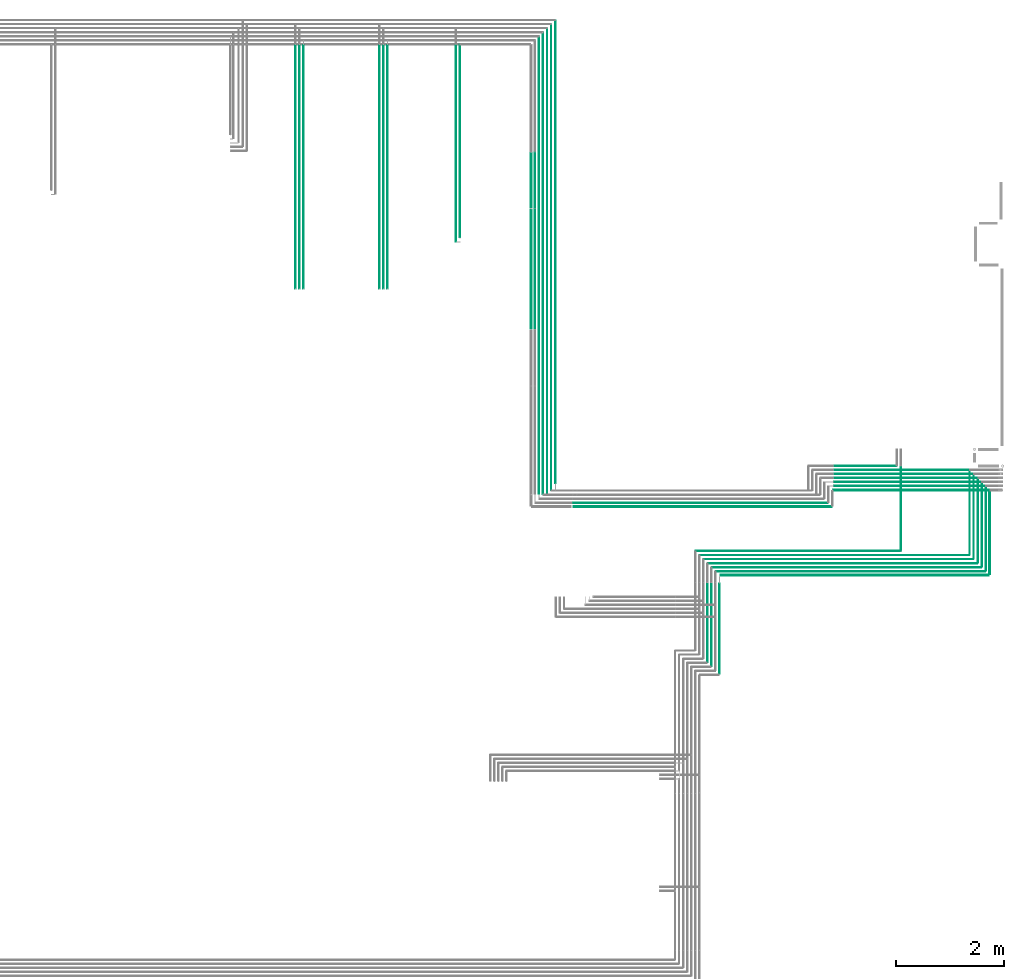
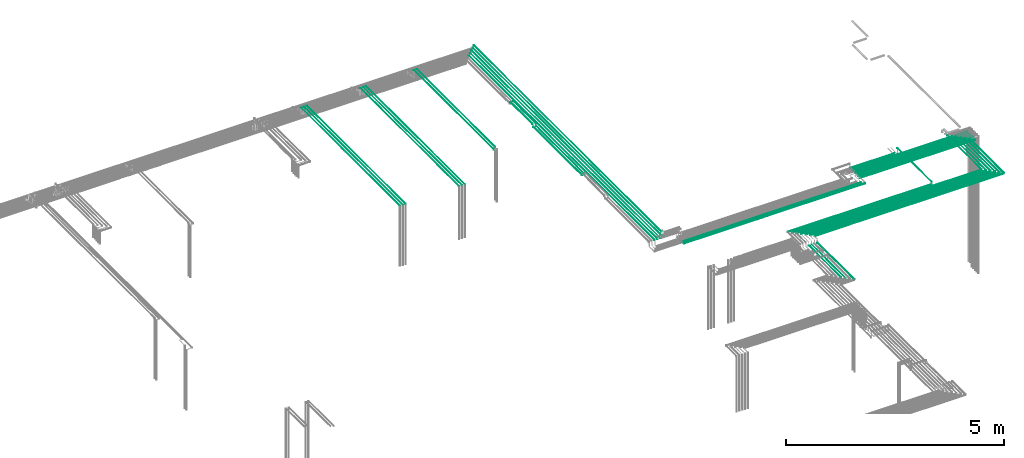
# One storey, part 30 of 89: 43 flow segments.
"""IFC2X3 building model written with IfcOpenShell, lengths in millimetres."""

from ifc_helpers import new_model, entity, si_unit, converted_unit, derived_unit, direction, frame, frame_2d, origin, origin_2d_with_axis, place, context, subcontext, project, spatial, circle, extrude, type_object, element, save


model = new_model("IFC2X3")

# Units and contexts
model_context = context("Model", 3, precision=0.01, world=origin(), true_north=direction((6.12303176911189e-17, 1.0)))
body_context = subcontext(model_context, "Body", "Model", "MODEL_VIEW")
ifc_project = project(units=[si_unit("LENGTHUNIT", "METRE", prefix="MILLI"), si_unit("AREAUNIT", "SQUARE_METRE"), si_unit("VOLUMEUNIT", "CUBIC_METRE"), converted_unit("PLANEANGLEUNIT", "DEGREE", entity("IfcRatioMeasure", 0.0174532925199433), si_unit("PLANEANGLEUNIT", "RADIAN"), dimensions=[0, 0, 0, 0, 0, 0, 0]), si_unit("MASSUNIT", "GRAM", prefix="KILO"), derived_unit("MASSDENSITYUNIT", [(si_unit("MASSUNIT", "GRAM", prefix="KILO"), 1), (si_unit("LENGTHUNIT", "METRE"), -3)]), derived_unit("MOMENTOFINERTIAUNIT", [(si_unit("LENGTHUNIT", "METRE"), 4)]), si_unit("TIMEUNIT", "SECOND"), si_unit("FREQUENCYUNIT", "HERTZ"), si_unit("THERMODYNAMICTEMPERATUREUNIT", "DEGREE_CELSIUS"), derived_unit("THERMALTRANSMITTANCEUNIT", [(si_unit("MASSUNIT", "GRAM", prefix="KILO"), 1), (si_unit("THERMODYNAMICTEMPERATUREUNIT", "KELVIN"), -1), (si_unit("TIMEUNIT", "SECOND"), -3)]), derived_unit("VOLUMETRICFLOWRATEUNIT", [(si_unit("LENGTHUNIT", "METRE"), 3), (si_unit("TIMEUNIT", "SECOND"), -1)]), derived_unit("MASSFLOWRATEUNIT", [(si_unit("MASSUNIT", "GRAM", prefix="KILO"), 1), (si_unit("TIMEUNIT", "SECOND"), -1)]), derived_unit("ROTATIONALFREQUENCYUNIT", [(si_unit("TIMEUNIT", "SECOND"), -1)]), si_unit("ELECTRICCURRENTUNIT", "AMPERE"), si_unit("ELECTRICVOLTAGEUNIT", "VOLT"), si_unit("POWERUNIT", "WATT"), si_unit("FORCEUNIT", "NEWTON", prefix="KILO"), si_unit("ILLUMINANCEUNIT", "LUX"), si_unit("LUMINOUSFLUXUNIT", "LUMEN"), si_unit("LUMINOUSINTENSITYUNIT", "CANDELA"), derived_unit("USERDEFINED", [(si_unit("MASSUNIT", "GRAM", prefix="KILO"), -1), (si_unit("LENGTHUNIT", "METRE"), -2), (si_unit("TIMEUNIT", "SECOND"), 3), (si_unit("LUMINOUSFLUXUNIT", "LUMEN"), 1)]), derived_unit("LINEARVELOCITYUNIT", [(si_unit("LENGTHUNIT", "METRE"), 1), (si_unit("TIMEUNIT", "SECOND"), -1)]), si_unit("PRESSUREUNIT", "PASCAL"), derived_unit("USERDEFINED", [(si_unit("LENGTHUNIT", "METRE"), -2), (si_unit("MASSUNIT", "GRAM", prefix="KILO"), 1), (si_unit("TIMEUNIT", "SECOND"), -2)]), derived_unit("LINEARFORCEUNIT", [(si_unit("MASSUNIT", "GRAM", prefix="KILO"), 1), (si_unit("LENGTHUNIT", "METRE"), 1), (si_unit("TIMEUNIT", "SECOND"), -2), (si_unit("LENGTHUNIT", "METRE"), -1)]), derived_unit("PLANARFORCEUNIT", [(si_unit("MASSUNIT", "GRAM", prefix="KILO"), 1), (si_unit("LENGTHUNIT", "METRE"), 1), (si_unit("TIMEUNIT", "SECOND"), -2), (si_unit("LENGTHUNIT", "METRE"), -2)])], contexts=[model_context])

# Site, building, storey
site_placement = place(None, frame((0.0, -0.00077364408347762, 0.0)))
site = spatial("IfcSite", under=ifc_project, at=site_placement, CompositionType="ELEMENT")
building_placement = place(site_placement, origin())
building = spatial("IfcBuilding", under=site, at=building_placement, CompositionType="ELEMENT")
storey_placement = place(building_placement, frame((0.0, 0.0, 24000.0)))
storey = spatial("IfcBuildingStorey", under=building, at=storey_placement, CompositionType="ELEMENT", Elevation=24000.0)

# Flow segments
pipe_segment_type = type_object("IfcPipeSegmentType", PredefinedType="NOTDEFINED")
flow_segment_1_placement = place(storey_placement, frame((73062.1514734655, 8793.95129953584, 2690.90472776409)))
element("IfcFlowSegment", 1, at=flow_segment_1_placement, inside=storey, type_object=pipe_segment_type, context=body_context, shape_type="SweptSolid", body=[
    extrude(circle(Radius=7.5, at=frame_2d((-8.66293703438714e-12, 0.0), x_axis=(1.0, 0.0))), frame((9.09527223594018, 0.0, 9.09527223591419), z_axis=(0.0, 1.0, 0.0), x_axis=(1.0, 0.0, 0.0)), (0.0, 0.0, 1.0), 1547.92034830156),
])
flow_segment_2_placement = place(storey_placement, frame((72916.050559081, 8935.95129953583, 2694.40472776409)))
element("IfcFlowSegment", 2, at=flow_segment_2_placement, inside=storey, type_object=pipe_segment_type, context=body_context, shape_type="SweptSolid", body=[
    extrude(circle(Radius=4.0, at=origin_2d_with_axis()), frame((5.59527223591499, 0.0, 5.59527223591499), z_axis=(0.0, 1.0, 0.0), x_axis=(1.0, 0.0, 0.0)), (0.0, 0.0, 1.0), 1563.74520630519),
])
flow_segment_3_placement = place(storey_placement, frame((72841.0505590676, 9010.95129953583, 2694.40472776409)))
element("IfcFlowSegment", 3, at=flow_segment_3_placement, inside=storey, type_object=pipe_segment_type, context=body_context, shape_type="SweptSolid", body=[
    extrude(circle(Radius=4.0, at=origin_2d_with_axis()), frame((5.59527223598429, 0.0, 5.59527223591499), z_axis=(0.0, 1.0, 0.0), x_axis=(1.0, 0.0, 0.0)), (0.0, 0.0, 1.0), 1563.98901522248),
])
flow_segment_4_placement = place(storey_placement, frame((72766.0505590676, 9085.95287992001, 2694.40472776415)))
element("IfcFlowSegment", 4, at=flow_segment_4_placement, inside=storey, type_object=pipe_segment_type, context=body_context, shape_type="SweptSolid", body=[
    extrude(circle(Radius=4.0, at=frame_2d((0.0, 6.10873375888857e-18), x_axis=(1.0, 0.0))), frame((5.59527223591499, 2.25650353826268e-05, 5.59527223585435), z_axis=(0.0, 1.0, 5.64125883370984e-06), x_axis=(-1.0, 0.0, 0.0)), (0.0, 0.0, 1.0), 1563.9225209192),
])
flow_segment_5_placement = place(storey_placement, frame((72691.0505590676, 9160.95129953583, 2694.40472776409)))
element("IfcFlowSegment", 5, at=flow_segment_5_placement, inside=storey, type_object=pipe_segment_type, context=body_context, shape_type="SweptSolid", body=[
    extrude(circle(Radius=4.0, at=origin_2d_with_axis()), frame((5.59527223591499, 0.0, 5.59527223591499), z_axis=(0.0, 1.0, 0.0), x_axis=(1.0, 0.0, 0.0)), (0.0, 0.0, 1.0), 1564.22554832766),
])
flow_segment_6_placement = place(storey_placement, frame((65334.0302365426, 10040.9047277637, 2665.90472776407)))
element("IfcFlowSegment", 6, at=flow_segment_6_placement, inside=storey, type_object=pipe_segment_type, context=body_context, shape_type="SweptSolid", body=[
    extrude(circle(Radius=7.5, at=frame_2d((-4.33146851719357e-12, 0.0), x_axis=(1.0, 0.0))), frame((0.0, 9.09527223591853, 9.09527223591419), z_axis=(1.0, 0.0, 0.0), x_axis=(0.0, 1.0, 0.0)), (0.0, 0.0, 1.0), 4792.68035740013),
])
flow_segment_7_placement = place(storey_placement, frame((67680.0002685548, 9145.35602729992, 2694.40472776408)))
element("IfcFlowSegment", 7, at=flow_segment_7_placement, inside=storey, type_object=pipe_segment_type, context=body_context, shape_type="SweptSolid", body=[
    extrude(circle(Radius=4.0, at=origin_2d_with_axis()), frame((0.0, 5.59527223594964, 5.59527223591499), z_axis=(1.0, 0.0, 0.0), x_axis=(0.0, -1.0, 0.0)), (0.0, 0.0, 1.0), 5006.6455627487),
])
flow_segment_8_placement = place(storey_placement, frame((72991.0505590676, 8860.9512995358, 2694.40472776409)))
element("IfcFlowSegment", 8, at=flow_segment_8_placement, inside=storey, type_object=pipe_segment_type, context=body_context, shape_type="SweptSolid", body=[
    extrude(circle(Radius=4.0, at=origin_2d_with_axis()), frame((5.59527224864085, 0.0, 5.59527223591499), z_axis=(0.0, 1.0, 0.0), x_axis=(1.0, 0.0, 0.0)), (0.0, 0.0, 1.0), 1556.86799522113),
])
flow_segment_9_placement = place(storey_placement, frame((65315.0302365425, 10119.4047277636, 2669.40472776407)))
element("IfcFlowSegment", 9, at=flow_segment_9_placement, inside=storey, type_object=pipe_segment_type, context=body_context, shape_type="SweptSolid", body=[
    extrude(circle(Radius=4.0, at=frame_2d((-4.54804194305325e-11, 0.0), x_axis=(1.0, 0.0))), frame((0.0, 5.59527223596264, 5.59527223591499), z_axis=(1.0, 0.0, 0.0), x_axis=(0.0, 1.0, 0.0)), (0.0, 0.0, 1.0), 4744.68035740013),
])
flow_segment_10_placement = place(storey_placement, frame((70162.7105939427, 10350.7766673957, 2615.90472776409)))
element("IfcFlowSegment", 10, at=flow_segment_10_placement, inside=storey, type_object=pipe_segment_type, context=body_context, shape_type="SweptSolid", body=[
    extrude(circle(Radius=7.5, at=frame_2d((2.16573425859679e-12, 0.0), x_axis=(1.0, 0.0))), frame((0.0, 9.09527223591853, 9.09527223591419), z_axis=(1.0, 0.0, 0.0), x_axis=(0.0, 1.0, 0.0)), (0.0, 0.0, 1.0), 3050.98693900199),
])
flow_segment_11_placement = place(storey_placement, frame((67830.0002685548, 8995.35602729992, 2694.40472776408)))
element("IfcFlowSegment", 11, at=flow_segment_11_placement, inside=storey, type_object=pipe_segment_type, context=body_context, shape_type="SweptSolid", body=[
    extrude(circle(Radius=4.0, at=origin_2d_with_axis()), frame((0.0, 5.59527223594964, 5.59527223591499), z_axis=(1.0, 0.0, 0.0), x_axis=(0.0, -1.0, 0.0)), (0.0, 0.0, 1.0), 5006.64556274878),
])
flow_segment_12_placement = place(storey_placement, frame((67905.0002685548, 8920.35602729992, 2694.40472776408)))
element("IfcFlowSegment", 12, at=flow_segment_12_placement, inside=storey, type_object=pipe_segment_type, context=body_context, shape_type="SweptSolid", body=[
    extrude(circle(Radius=4.0, at=origin_2d_with_axis()), frame((0.0, 5.59527223595073, 5.59527223591499), z_axis=(1.0, 0.0, 0.0), x_axis=(0.0, -1.0, 0.0)), (0.0, 0.0, 1.0), 5006.64556276213),
])
flow_segment_13_placement = place(storey_placement, frame((67755.0002685548, 9070.35763024912, 2694.40472776408)))
element("IfcFlowSegment", 13, at=flow_segment_13_placement, inside=storey, type_object=pipe_segment_type, context=body_context, shape_type="SweptSolid", body=[
    extrude(circle(Radius=4.0, at=origin_2d_with_axis()), frame((0.0, 5.5952722359269, 5.59527223591499), z_axis=(1.0, 0.0, 0.0), x_axis=(0.0, -1.0, 0.0)), (0.0, 0.0, 1.0), 5006.64556274871),
])
flow_segment_14_placement = place(storey_placement, frame((71415.5699397461, 9235.95129951454, 2744.40472776409)))
element("IfcFlowSegment", 14, at=flow_segment_14_placement, inside=storey, type_object=pipe_segment_type, context=body_context, shape_type="SweptSolid", body=[
    extrude(circle(Radius=4.0, at=origin_2d_with_axis()), frame((5.59527223591499, 0.0, 5.59527223591499), z_axis=(0.0, 1.0, 0.0), x_axis=(-1.0, 0.0, 0.0)), (0.0, 0.0, 1.0), 1563.91970228856),
])
flow_segment_15_placement = place(storey_placement, frame((68063.0002685548, 8766.85602729991, 2690.90472776408)))
element("IfcFlowSegment", 15, at=flow_segment_15_placement, inside=storey, type_object=pipe_segment_type, context=body_context, shape_type="SweptSolid", body=[
    extrude(circle(Radius=7.5, at=origin_2d_with_axis()), frame((0.0, 9.09527223591636, 9.09527223591419), z_axis=(1.0, 0.0, 0.0), x_axis=(0.0, -1.0, 0.0)), (0.0, 0.0, 1.0), 4990.24647714661),
])
flow_segment_16_placement = place(storey_placement, frame((68035.9049963189, 6943.0, 2590.90472776409)))
element("IfcFlowSegment", 16, at=flow_segment_16_placement, inside=storey, type_object=pipe_segment_type, context=body_context, shape_type="SweptSolid", body=[
    extrude(circle(Radius=7.5, at=origin_2d_with_axis()), frame((9.09527223595751, 0.0, 9.09527223591419), z_axis=(0.0, 1.0, 0.0), x_axis=(1.0, 0.0, 0.0)), (0.0, 0.0, 1.0), 1679.00000000001),
])
flow_segment_17_placement = place(storey_placement, frame((67980.0002685548, 8845.35602729992, 2694.40472776408)))
element("IfcFlowSegment", 17, at=flow_segment_17_placement, inside=storey, type_object=pipe_segment_type, context=body_context, shape_type="SweptSolid", body=[
    extrude(circle(Radius=4.0, at=origin_2d_with_axis()), frame((0.0, 5.5952722359269, 5.59527223591499), z_axis=(1.0, 0.0, 0.0), x_axis=(0.0, -1.0, 0.0)), (0.0, 0.0, 1.0), 5006.64556276142),
])
flow_segment_18_placement = place(storey_placement, frame((67889.4049963189, 7085.0, 2594.40472776409)))
element("IfcFlowSegment", 18, at=flow_segment_18_placement, inside=storey, type_object=pipe_segment_type, context=body_context, shape_type="SweptSolid", body=[
    extrude(circle(Radius=4.0, at=origin_2d_with_axis()), frame((5.59527223593232, 0.0, 5.59527223591499), z_axis=(0.0, 1.0, 0.0), x_axis=(1.0, 0.0, 0.0)), (0.0, 0.0, 1.0), 1545.00000000001),
])
flow_segment_19_placement = place(storey_placement, frame((67814.4049963189, 7160.0, 2594.40472776409)))
element("IfcFlowSegment", 19, at=flow_segment_19_placement, inside=storey, type_object=pipe_segment_type, context=body_context, shape_type="SweptSolid", body=[
    extrude(circle(Radius=4.0, at=origin_2d_with_axis()), frame((5.59527223593232, 0.0, 5.59527223591499), z_axis=(0.0, 1.0, 0.0), x_axis=(1.0, 0.0, 0.0)), (0.0, 0.0, 1.0), 1470.00000000001),
])
flow_segment_20_placement = place(storey_placement, frame((67605.0002685548, 9220.35602727861, 2694.40472776408)))
element("IfcFlowSegment", 20, at=flow_segment_20_placement, inside=storey, type_object=pipe_segment_type, context=body_context, shape_type="SweptSolid", body=[
    extrude(circle(Radius=4.0, at=origin_2d_with_axis()), frame((0.0, 5.59527223594964, 5.59527223591499), z_axis=(1.0, 0.0, 0.0), x_axis=(0.0, -1.0, 0.0)), (0.0, 0.0, 1.0), 3806.16494342721),
])
flow_segment_21_placement = place(storey_placement, frame((64984.2044210321, 10490.0, 2844.4047277641)))
element("IfcFlowSegment", 21, at=flow_segment_21_placement, inside=storey, type_object=pipe_segment_type, context=body_context, shape_type="SweptSolid", body=[
    extrude(circle(Radius=4.0, at=origin_2d_with_axis()), frame((5.59527223591499, 0.0, 5.59527223591499), z_axis=(0.0, 1.0, 0.0), x_axis=(-1.0, 0.0, 0.0)), (0.0, 0.0, 1.0), 8600.00000000001),
])
flow_segment_22_placement = place(storey_placement, frame((64909.2044210321, 10360.0, 2844.4047277641)))
element("IfcFlowSegment", 22, at=flow_segment_22_placement, inside=storey, type_object=pipe_segment_type, context=body_context, shape_type="SweptSolid", body=[
    extrude(circle(Radius=4.0, at=frame_2d((8.66293703438714e-12, 0.0), x_axis=(1.0, 0.0))), frame((5.59527223592365, 0.0, 5.59527223591499), z_axis=(0.0, 1.0, 0.0), x_axis=(-1.0, 0.0, 0.0)), (0.0, 0.0, 1.0), 8655.00000000045),
])
flow_segment_23_placement = place(storey_placement, frame((64834.2044210321, 10285.0, 2844.4047277641)))
element("IfcFlowSegment", 23, at=flow_segment_23_placement, inside=storey, type_object=pipe_segment_type, context=body_context, shape_type="SweptSolid", body=[
    extrude(circle(Radius=4.0, at=frame_2d((8.66293703438714e-12, 0.0), x_axis=(1.0, 0.0))), frame((5.59527223591499, 0.0, 5.59527223591499), z_axis=(0.0, 1.0, 0.0), x_axis=(-1.0, 0.0, 0.0)), (0.0, 0.0, 1.0), 8655.00000000046),
])
flow_segment_24_placement = place(storey_placement, frame((64759.2044210321, 10285.0, 2844.4047277641)))
element("IfcFlowSegment", 24, at=flow_segment_24_placement, inside=storey, type_object=pipe_segment_type, context=body_context, shape_type="SweptSolid", body=[
    extrude(circle(Radius=4.0, at=frame_2d((8.66293703438714e-12, 0.0), x_axis=(1.0, 0.0))), frame((5.59527223591499, 0.0, 5.59527223591499), z_axis=(0.0, 1.0, 0.0), x_axis=(-1.0, 0.0, 0.0)), (0.0, 0.0, 1.0), 8580.00000000046),
])
flow_segment_25_placement = place(storey_placement, frame((64684.4898186752, 10292.0, 2844.4047277641)))
element("IfcFlowSegment", 25, at=flow_segment_25_placement, inside=storey, type_object=pipe_segment_type, context=body_context, shape_type="SweptSolid", body=[
    extrude(circle(Radius=4.0, at=frame_2d((8.66293703438714e-12, 0.0), x_axis=(1.0, 0.0))), frame((5.59527223591499, 0.0, 5.59527223591499), z_axis=(0.0, 1.0, 0.0), x_axis=(-1.0, 0.0, 0.0)), (0.0, 0.0, 1.0), 8498.00000000046),
])
flow_segment_26_placement = place(storey_placement, frame((64609.4898186752, 15606.8231771437, 2904.40472776415)))
element("IfcFlowSegment", 26, at=flow_segment_26_placement, inside=storey, type_object=pipe_segment_type, context=body_context, shape_type="SweptSolid", body=[
    extrude(circle(Radius=4.0, at=origin_2d_with_axis()), frame((5.59527223591499, 0.0, 5.59527223591499), z_axis=(0.0, 1.0, 0.0), x_axis=(-1.0, 0.0, 0.0)), (0.0, 0.0, 1.0), 1030.00000000003),
])
flow_segment_27_placement = place(storey_placement, frame((64609.4898186752, 13357.1551244193, 2844.40472776409)))
element("IfcFlowSegment", 27, at=flow_segment_27_placement, inside=storey, type_object=pipe_segment_type, context=body_context, shape_type="SweptSolid", body=[
    extrude(circle(Radius=4.0, at=origin_2d_with_axis()), frame((5.59527223591499, 0.0, 5.59527223591499), z_axis=(0.0, 1.0, 0.0), x_axis=(1.0, 0.0, 0.0)), (0.0, 0.0, 1.0), 2229.66805272439),
])
flow_segment_28_placement = place(storey_placement, frame((64530.9898186752, 15625.8231771437, 2900.90472776416)))
element("IfcFlowSegment", 28, at=flow_segment_28_placement, inside=storey, type_object=pipe_segment_type, context=body_context, shape_type="SweptSolid", body=[
    extrude(circle(Radius=7.5, at=frame_2d((-8.66293703438714e-12, 0.0), x_axis=(1.0, 0.0))), frame((9.09527223592286, 0.0, 9.09527223591419), z_axis=(0.0, 1.0, 0.0), x_axis=(-1.0, 0.0, 0.0)), (0.0, 0.0, 1.0), 1003.00000000002),
])
flow_segment_29_placement = place(storey_placement, frame((64530.9898186752, 13365.1551244193, 2840.90472776409)))
element("IfcFlowSegment", 29, at=flow_segment_29_placement, inside=storey, type_object=pipe_segment_type, context=body_context, shape_type="SweptSolid", body=[
    extrude(circle(Radius=7.5, at=frame_2d((-8.66293703438714e-12, 0.0), x_axis=(1.0, 0.0))), frame((9.09527223592286, 0.0, 9.09527223591419), z_axis=(0.0, 1.0, 0.0), x_axis=(1.0, 0.0, 0.0)), (0.0, 0.0, 1.0), 2213.66805272439),
])
flow_segment_30_placement = place(storey_placement, frame((63215.6186953096, 15059.7000254876, 3069.40472776409)))
element("IfcFlowSegment", 30, at=flow_segment_30_placement, inside=storey, type_object=pipe_segment_type, context=body_context, shape_type="SweptSolid", body=[
    extrude(circle(Radius=4.0, at=frame_2d((5.19776222063229e-11, 0.0), x_axis=(1.0, 0.0))), frame((5.59527223596697, 0.0, 5.59527223591499), z_axis=(0.0, 1.0, 0.0), x_axis=(-1.0, 0.0, 0.0)), (0.0, 0.0, 1.0), 3580.29997451247),
])
flow_segment_31_placement = place(storey_placement, frame((61790.6539188809, 14109.999966659, 3069.40472776409)))
element("IfcFlowSegment", 31, at=flow_segment_31_placement, inside=storey, type_object=pipe_segment_type, context=body_context, shape_type="SweptSolid", body=[
    extrude(circle(Radius=4.0, at=origin_2d_with_axis()), frame((5.62470878275058, 2.60318788946279e-05, 5.59527223591499), z_axis=(-6.50796983339842e-06, 1.0, 0.0), x_axis=(1.0, 6.50796983339842e-06, 0.0)), (0.0, 0.0, 1.0), 4523.15356029304),
])
flow_segment_32_placement = place(storey_placement, frame((61715.594895382, 14109.9999404935, 3069.40472776409)))
element("IfcFlowSegment", 32, at=flow_segment_32_placement, inside=storey, type_object=pipe_segment_type, context=body_context, shape_type="SweptSolid", body=[
    extrude(circle(Radius=4.0, at=frame_2d((-8.6629652947317e-12, 0.0), x_axis=(1.0, 0.0))), frame((5.5952722355858, 5.21967663587475e-05, 5.59527223591499), z_axis=(1.30491919821529e-05, 1.0, 0.0), x_axis=(1.0, -1.30491919821529e-05, 0.0)), (0.0, 0.0, 1.0), 4523.15360278613),
])
flow_segment_33_placement = place(storey_placement, frame((61865.5947019486, 14109.999940323, 3069.4047277641)))
element("IfcFlowSegment", 33, at=flow_segment_33_placement, inside=storey, type_object=pipe_segment_type, context=body_context, shape_type="SweptSolid", body=[
    extrude(circle(Radius=4.0, at=frame_2d((-2.83537000829725e-17, 0.0), x_axis=(1.0, 0.0))), frame((5.59527223557714, 5.23678268791628e-05, 5.59527223591499), z_axis=(1.30919571366726e-05, 1.0, 0.0), x_axis=(1.0, -1.30919571366726e-05, 0.0)), (0.0, 0.0, 1.0), 4523.15356058489),
])
flow_segment_34_placement = place(storey_placement, frame((60225.0831235945, 14109.999966659, 3069.40472776409)))
element("IfcFlowSegment", 34, at=flow_segment_34_placement, inside=storey, type_object=pipe_segment_type, context=body_context, shape_type="SweptSolid", body=[
    extrude(circle(Radius=4.0, at=origin_2d_with_axis()), frame((5.62470878275058, 2.60318788946279e-05, 5.59527223591499), z_axis=(-6.50796983339842e-06, 1.0, 0.0), x_axis=(1.0, 6.50796983339842e-06, 0.0)), (0.0, 0.0, 1.0), 4523.15356029304),
])
flow_segment_35_placement = place(storey_placement, frame((60150.0241000956, 14109.9999404935, 3069.40472776409)))
element("IfcFlowSegment", 35, at=flow_segment_35_placement, inside=storey, type_object=pipe_segment_type, context=body_context, shape_type="SweptSolid", body=[
    extrude(circle(Radius=4.0, at=frame_2d((-2.82610821227549e-17, 0.0), x_axis=(1.0, 0.0))), frame((5.5952722355858, 5.21967663587475e-05, 5.59527223591499), z_axis=(1.30491919821529e-05, 1.0, 0.0), x_axis=(1.0, -1.30491919821529e-05, 0.0)), (0.0, 0.0, 1.0), 4523.15360278613),
])
flow_segment_36_placement = place(storey_placement, frame((60300.0239066622, 14109.999940323, 3069.4047277641)))
element("IfcFlowSegment", 36, at=flow_segment_36_placement, inside=storey, type_object=pipe_segment_type, context=body_context, shape_type="SweptSolid", body=[
    extrude(circle(Radius=4.0, at=frame_2d((-8.66293703364473e-12, 0.0), x_axis=(1.0, 0.0))), frame((5.5952722355858, 5.2367829044897e-05, 5.59527223591499), z_axis=(1.30919571366726e-05, 1.0, 0.0), x_axis=(1.0, -1.30919571366726e-05, 0.0)), (0.0, 0.0, 1.0), 4523.15356058489),
])
flow_segment_37_placement = place(storey_placement, frame((63140.6191645204, 14984.7000254193, 3069.40472776409)))
element("IfcFlowSegment", 37, at=flow_segment_37_placement, inside=storey, type_object=pipe_segment_type, context=body_context, shape_type="SweptSolid", body=[
    extrude(circle(Radius=4.0, at=origin_2d_with_axis()), frame((5.59533462666473, 6.82747725022637e-08, 5.59527223591499), z_axis=(-1.70685693397906e-08, 1.0, 0.0), x_axis=(-1.0, -1.70685693397906e-08, 0.0)), (0.0, 0.0, 1.0), 3655.29997451267),
])
flow_segment_38_placement = place(storey_placement, frame((70172.7097487357, 10804.2778735408, 2619.4047277641)))
element("IfcFlowSegment", 38, at=flow_segment_38_placement, inside=storey, type_object=pipe_segment_type, context=body_context, shape_type="SweptSolid", body=[
    extrude(circle(Radius=4.0, at=origin_2d_with_axis()), frame((0.00084498378794251, 5.59527214666508, 5.59527223591499), z_axis=(0.999999977687574, 0.000211245949459681, 0.0), x_axis=(-0.000211245949459681, 0.999999977687574, 0.0)), (0.0, 0.0, 1.0), 1163.45464444511),
])
flow_segment_39_placement = place(storey_placement, frame((70179.7105927685, 10729.580627463, 2619.40472776409)))
element("IfcFlowSegment", 39, at=flow_segment_39_placement, inside=storey, type_object=pipe_segment_type, context=body_context, shape_type="SweptSolid", body=[
    extrude(circle(Radius=4.0, at=origin_2d_with_axis()), frame((1.17414849682973e-06, 5.59616517300755, 5.59527223591499), z_axis=(1.0, -2.93537451164316e-07, 0.0), x_axis=(2.93537451164316e-07, 1.0, 0.0)), (0.0, 0.0, 1.0), 3041.98693904155),
])
flow_segment_40_placement = place(storey_placement, frame((70179.7105939427, 10654.28176996, 2619.40472776409)))
element("IfcFlowSegment", 40, at=flow_segment_40_placement, inside=storey, type_object=pipe_segment_type, context=body_context, shape_type="SweptSolid", body=[
    extrude(circle(Radius=4.0, at=frame_2d((-4.33146851719357e-12, 0.0), x_axis=(1.0, 0.0))), frame((0.0, 5.59527223591932, 5.59527223591499), z_axis=(1.0, 0.0, 0.0), x_axis=(0.0, 1.0, 0.0)), (0.0, 0.0, 1.0), 3041.98693899978),
])
flow_segment_41_placement = place(storey_placement, frame((70179.7105939427, 10579.3450681644, 2619.40472776409)))
element("IfcFlowSegment", 41, at=flow_segment_41_placement, inside=storey, type_object=pipe_segment_type, context=body_context, shape_type="SweptSolid", body=[
    extrude(circle(Radius=4.0, at=frame_2d((-4.33146851719357e-12, 0.0), x_axis=(1.0, 0.0))), frame((0.0, 5.59527223591932, 5.59527223591499), z_axis=(1.0, 0.0, 0.0), x_axis=(0.0, 1.0, 0.0)), (0.0, 0.0, 1.0), 3041.98693900199),
])
flow_segment_42_placement = place(storey_placement, frame((70179.7105939427, 10504.2761990331, 2619.40472776409)))
element("IfcFlowSegment", 42, at=flow_segment_42_placement, inside=storey, type_object=pipe_segment_type, context=body_context, shape_type="SweptSolid", body=[
    extrude(circle(Radius=4.0, at=frame_2d((-4.33146851719357e-12, 0.0), x_axis=(1.0, 0.0))), frame((0.0, 5.59527223591932, 5.59527223591499), z_axis=(1.0, 0.0, 0.0), x_axis=(0.0, 1.0, 0.0)), (0.0, 0.0, 1.0), 3041.986939002),
])
flow_segment_43_placement = place(storey_placement, frame((70172.7105939427, 10429.2757609921, 2619.40472776409)))
element("IfcFlowSegment", 43, at=flow_segment_43_placement, inside=storey, type_object=pipe_segment_type, context=body_context, shape_type="SweptSolid", body=[
    extrude(circle(Radius=4.0, at=frame_2d((-2.16573425859679e-12, 0.0), x_axis=(1.0, 0.0))), frame((0.0, 5.59527223591932, 5.59527223591499), z_axis=(1.0, 0.0, 0.0), x_axis=(0.0, 1.0, 0.0)), (0.0, 0.0, 1.0), 3048.98693900199),
])

save(model, "model.ifc")
